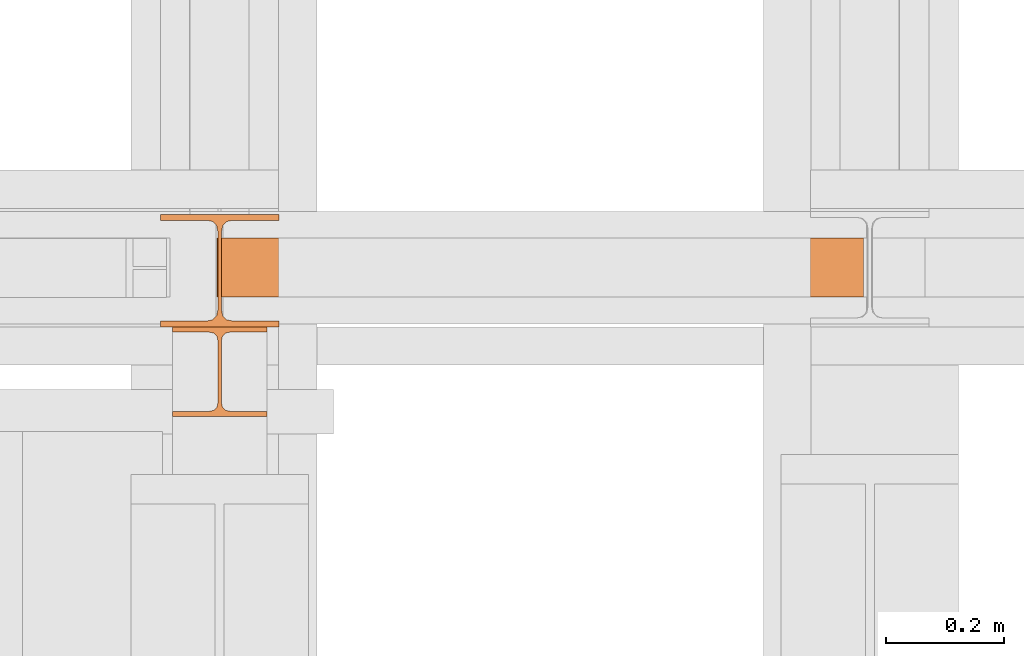
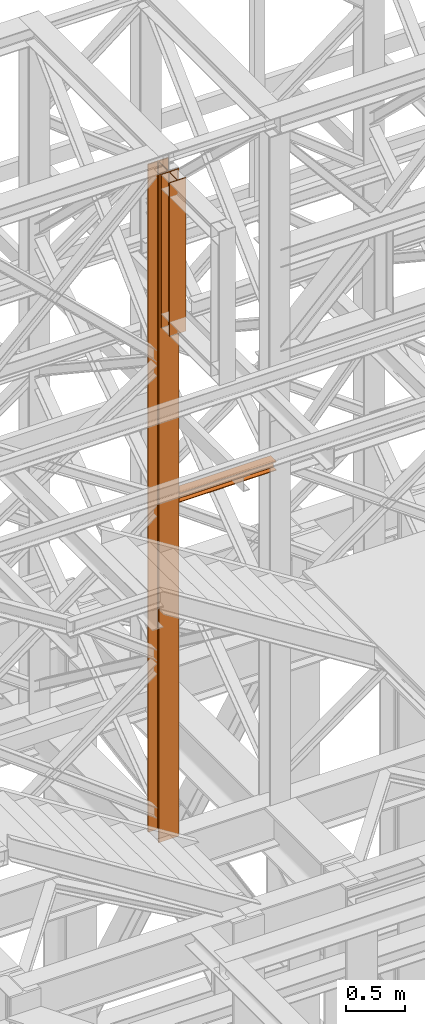
# One storey, part 91 of 208: 3 proxies.
"""IFC2X3 building model written with IfcOpenShell, lengths in millimetres."""

from ifc_helpers import new_model, entity, si_unit, converted_unit, frame, origin, origin_with_axes, place, context, subcontext, project, spatial, faceted_brep, element, save


model = new_model("IFC2X3")

# Units and contexts
model_context = context("Model", 3, precision=1e-05, world=origin())
plan_context = context("Plan", 3, precision=1e-05, world=origin())
body_context = subcontext(model_context, "Body", "Model", "MODEL_VIEW")
ifc_project = project(units=[si_unit("LENGTHUNIT", "METRE", prefix="MILLI"), converted_unit("PLANEANGLEUNIT", "DEGREE", entity("IfcPlaneAngleMeasure", 0.0174532925199433), si_unit("PLANEANGLEUNIT", "RADIAN"), dimensions=[0, 0, 0, 0, 0, 0, 0]), si_unit("AREAUNIT", "SQUARE_METRE"), si_unit("VOLUMEUNIT", "CUBIC_METRE")], contexts=[model_context, plan_context])

# Building, storey
building_placement = place(None, origin())
building = spatial("IfcBuilding", under=ifc_project, at=building_placement, CompositionType="COMPLEX")
storey_placement = place(building_placement, origin_with_axes())
storey = spatial("IfcBuildingStorey", under=building, at=storey_placement, Name="Geschoss", CompositionType="ELEMENT")

# Proxies
proxy_1_placement = place(storey_placement, frame((-1206.582754329112, -16062.574391808, 5284.990005364419), z_axis=(0.0, 0.0, 1.0), x_axis=(1.0, 0.0, 0.0)))
element("IfcBuildingElementProxy", 1, at=proxy_1_placement, inside=storey, context=body_context, shape_type="Brep", body=[
    faceted_brep([(0.009999999999990905, 190.0100125169756, 6965.010053329391), (200.0100029802322, 190.0100125169756, 6965.010053329391), (200.0100029802322, 180.0100146031382, 6965.010053329391), (121.2600035762787, 180.0100071525576, 6965.010053329391), (111.9441915473342, 178.1454621052744, 6965.010053329391), (105.1245498640835, 171.3258190250399, 6965.010053329391), (103.2600015571713, 162.010007927418, 6965.010053329391), (103.2600015571713, 28.00999713897727, 6965.010053329391), (105.1245498640835, 18.69418604135535, 6965.010053329391), (111.9441915473342, 11.87454296112082, 6965.010053329391), (121.2600035762787, 10.00999791383765, 6965.010053329391), (200.0100029802322, 10.00999791383765, 6965.010053329391), (200.0100029802322, 0.01000000000021828, 6965.010053329391), (0.009999999999990905, 0.01000000000021828, 6965.010053329391), (0.009999999999990905, 10.00999791383765, 6965.010053329391), (78.75999940395354, 10.00999791383765, 6965.010053329391), (88.07581143289804, 11.87454296112082, 6965.010053329391), (94.8954531161487, 18.69418604135535, 6965.010053329391), (96.76000142306088, 28.00999713897727, 6965.010053329391), (96.76000142306088, 162.010007927418, 6965.010053329391), (94.8954531161487, 171.3258190250399, 6965.010053329391), (88.07581143289804, 178.1454621052744, 6965.010053329391), (78.75999940395354, 180.0100071525576, 6965.010053329391), (0.009999999999990905, 180.0100146031382, 6965.010053329391), (200.0100029802322, 190.0100125169756, 6965.010053329391), (0.009999999999990905, 190.0100125169756, 6965.010053329391), (0.009999999999990905, 190.0100125169756, 0.009999999999308784), (200.0100029802322, 190.0100125169756, 0.009999999999308784), (200.0100029802322, 180.0100146031382, 6965.010053329391), (200.0100029802322, 190.0100125169756, 6965.010053329391), (200.0100029802322, 190.0100125169756, 0.009999999999308784), (200.0100029802322, 180.0100146031382, 0.009999999999308784), (121.2600035762787, 180.0100071525576, 6965.010053329391), (200.0100029802322, 180.0100146031382, 6965.010053329391), (200.0100029802322, 180.0100146031382, 0.009999999999308784), (121.2600035762787, 180.0100071525576, 0.009999999999308784), (111.9441915473342, 178.1454621052744, 6965.010053329391), (121.2600035762787, 180.0100071525576, 6965.010053329391), (121.2600035762787, 180.0100071525576, 0.009999999999308784), (111.9441915473342, 178.1454621052744, 0.009999999999308784), (105.1245498640835, 171.3258190250399, 6965.010053329391), (111.9441915473342, 178.1454621052744, 6965.010053329391), (111.9441915473342, 178.1454621052744, 0.009999999999308784), (105.1245498640835, 171.3258190250399, 0.009999999999308784), (103.2600015571713, 162.010007927418, 6965.010053329391), (105.1245498640835, 171.3258190250399, 6965.010053329391), (105.1245498640835, 171.3258190250399, 0.009999999999308784), (103.2600015571713, 162.010007927418, 0.009999999999308784), (103.2600015571713, 28.00999713897727, 6965.010053329391), (103.2600015571713, 162.010007927418, 6965.010053329391), (103.2600015571713, 162.010007927418, 0.009999999999308784), (103.2600015571713, 28.00999713897727, 0.009999999999308784), (105.1245498640835, 18.69418604135535, 6965.010053329391), (103.2600015571713, 28.00999713897727, 6965.010053329391), (103.2600015571713, 28.00999713897727, 0.009999999999308784), (105.1245498640835, 18.69418604135535, 0.009999999999308784), (111.9441915473342, 11.87454296112082, 6965.010053329391), (105.1245498640835, 18.69418604135535, 6965.010053329391), (105.1245498640835, 18.69418604135535, 0.009999999999308784), (111.9441915473342, 11.87454296112082, 0.009999999999308784), (121.2600035762787, 10.00999791383765, 6965.010053329391), (111.9441915473342, 11.87454296112082, 6965.010053329391), (111.9441915473342, 11.87454296112082, 0.009999999999308784), (121.2600035762787, 10.00999791383765, 0.009999999999308784), (200.0100029802322, 10.00999791383765, 6965.010053329391), (121.2600035762787, 10.00999791383765, 6965.010053329391), (121.2600035762787, 10.00999791383765, 0.009999999999308784), (200.0100029802322, 10.00999791383765, 0.009999999999308784), (200.0100029802322, 0.01000000000021828, 6965.010053329391), (200.0100029802322, 10.00999791383765, 6965.010053329391), (200.0100029802322, 10.00999791383765, 0.009999999999308784), (200.0100029802322, 0.01000000000021828, 0.009999999999308784), (0.009999999999990905, 0.01000000000021828, 6965.010053329391), (200.0100029802322, 0.01000000000021828, 6965.010053329391), (200.0100029802322, 0.01000000000021828, 0.009999999999308784), (0.009999999999990905, 0.01000000000021828, 0.009999999999308784), (0.009999999999990905, 10.00999791383765, 6965.010053329391), (0.009999999999990905, 0.01000000000021828, 6965.010053329391), (0.009999999999990905, 0.01000000000021828, 0.009999999999308784), (0.009999999999990905, 10.00999791383765, 0.009999999999308784), (78.75999940395354, 10.00999791383765, 6965.010053329391), (0.009999999999990905, 10.00999791383765, 6965.010053329391), (0.009999999999990905, 10.00999791383765, 0.009999999999308784), (78.75999940395354, 10.00999791383765, 0.009999999999308784), (88.07581143289804, 11.87454296112082, 6965.010053329391), (78.75999940395354, 10.00999791383765, 6965.010053329391), (78.75999940395354, 10.00999791383765, 0.009999999999308784), (88.07581143289804, 11.87454296112082, 0.009999999999308784), (94.8954531161487, 18.69418604135535, 6965.010053329391), (88.07581143289804, 11.87454296112082, 6965.010053329391), (88.07581143289804, 11.87454296112082, 0.009999999999308784), (94.8954531161487, 18.69418604135535, 0.009999999999308784), (96.76000142306088, 28.00999713897727, 6965.010053329391), (94.8954531161487, 18.69418604135535, 6965.010053329391), (94.8954531161487, 18.69418604135535, 0.009999999999308784), (96.76000142306088, 28.00999713897727, 0.009999999999308784), (96.76000142306088, 162.010007927418, 6965.010053329391), (96.76000142306088, 28.00999713897727, 6965.010053329391), (96.76000142306088, 28.00999713897727, 0.009999999999308784), (96.76000142306088, 162.010007927418, 0.009999999999308784), (94.8954531161487, 171.3258190250399, 6965.010053329391), (96.76000142306088, 162.010007927418, 6965.010053329391), (96.76000142306088, 162.010007927418, 0.009999999999308784), (94.8954531161487, 171.3258190250399, 0.009999999999308784), (88.07581143289804, 178.1454621052744, 6965.010053329391), (94.8954531161487, 171.3258190250399, 6965.010053329391), (94.8954531161487, 171.3258190250399, 0.009999999999308784), (88.07581143289804, 178.1454621052744, 0.009999999999308784), (78.75999940395354, 180.0100071525576, 6965.010053329391), (88.07581143289804, 178.1454621052744, 6965.010053329391), (88.07581143289804, 178.1454621052744, 0.009999999999308784), (78.75999940395354, 180.0100071525576, 0.009999999999308784), (0.009999999999990905, 180.0100146031382, 6965.010053329391), (78.75999940395354, 180.0100071525576, 6965.010053329391), (78.75999940395354, 180.0100071525576, 0.009999999999308784), (0.009999999999990905, 180.0100146031382, 0.009999999999308784), (0.009999999999990905, 190.0100125169756, 6965.010053329391), (0.009999999999990905, 180.0100146031382, 6965.010053329391), (0.009999999999990905, 180.0100146031382, 0.009999999999308784), (0.009999999999990905, 190.0100125169756, 0.009999999999308784), (0.009999999999990905, 190.0100125169756, 0.009999999999308784), (0.009999999999990905, 180.0100146031382, 0.009999999999308784), (78.75999940395354, 180.0100071525576, 0.009999999999308784), (88.07581143289804, 178.1454621052744, 0.009999999999308784), (94.8954531161487, 171.3258190250399, 0.009999999999308784), (96.76000142306088, 162.010007927418, 0.009999999999308784), (96.76000142306088, 28.00999713897727, 0.009999999999308784), (94.8954531161487, 18.69418604135535, 0.009999999999308784), (88.07581143289804, 11.87454296112082, 0.009999999999308784), (78.75999940395354, 10.00999791383765, 0.009999999999308784), (0.009999999999990905, 10.00999791383765, 0.009999999999308784), (0.009999999999990905, 0.01000000000021828, 0.009999999999308784), (200.0100029802322, 0.01000000000021828, 0.009999999999308784), (200.0100029802322, 10.00999791383765, 0.009999999999308784), (121.2600035762787, 10.00999791383765, 0.009999999999308784), (111.9441915473342, 11.87454296112082, 0.009999999999308784), (105.1245498640835, 18.69418604135535, 0.009999999999308784), (103.2600015571713, 28.00999713897727, 0.009999999999308784), (103.2600015571713, 162.010007927418, 0.009999999999308784), (105.1245498640835, 171.3258190250399, 0.009999999999308784), (111.9441915473342, 178.1454621052744, 0.009999999999308784), (121.2600035762787, 180.0100071525576, 0.009999999999308784), (200.0100029802322, 180.0100146031382, 0.009999999999308784), (200.0100029802322, 190.0100125169756, 0.009999999999308784)], [[[0, 1, 2, 3, 4, 5, 6, 7, 8, 9, 10, 11, 12, 13, 14, 15, 16, 17, 18, 19, 20, 21, 22, 23]], [[24, 25, 26, 27]], [[28, 29, 30, 31]], [[32, 33, 34, 35]], [[36, 37, 38, 39]], [[40, 41, 42, 43]], [[44, 45, 46, 47]], [[48, 49, 50, 51]], [[52, 53, 54, 55]], [[56, 57, 58, 59]], [[60, 61, 62, 63]], [[64, 65, 66, 67]], [[68, 69, 70, 71]], [[72, 73, 74, 75]], [[76, 77, 78, 79]], [[80, 81, 82, 83]], [[84, 85, 86, 87]], [[88, 89, 90, 91]], [[92, 93, 94, 95]], [[96, 97, 98, 99]], [[100, 101, 102, 103]], [[104, 105, 106, 107]], [[108, 109, 110, 111]], [[112, 113, 114, 115]], [[116, 117, 118, 119]], [[120, 121, 122, 123, 124, 125, 126, 127, 128, 129, 130, 131, 132, 133, 134, 135, 136, 137, 138, 139, 140, 141, 142, 143]]], orient=[[False], [False], [False], [False], [False], [False], [False], [False], [False], [False], [False], [False], [False], [False], [False], [False], [False], [False], [False], [False], [False], [False], [False], [False], [False], [False]]),
])
proxy_2_placement = place(storey_placement, frame((-1111.071256267099, -16012.50587051043, 8720.799696083517), z_axis=(0.0, 0.0, 1.0), x_axis=(1.0, 0.0, 0.0)))
element("IfcBuildingElementProxy", 2, at=proxy_2_placement, inside=storey, context=body_context, shape_type="Brep", body=[
    faceted_brep([(1093.509999865889, 0.01000000000021828, 88.01000000000022), (1093.509999865889, 0.01000000000021828, 96.01000000000022), (1093.509999865889, 100.0100000000002, 96.01000000000022), (1093.509999865889, 100.0100000000002, 88.01000000000022), (1093.509999865889, 52.51000000000022, 88.01000000000022), (1093.509999865889, 52.51000000000022, 8.010000000000218), (1093.509999865889, 100.0100000000002, 8.010000000000218), (1093.509999865889, 100.0100000000002, 0.01000000000021828), (1093.509999865889, 0.01000000000021828, 0.01000000000021828), (1093.509999865889, 0.01000000000021828, 8.010000000000218), (1093.509999865889, 47.51000000000022, 8.010000000000218), (1093.509999865889, 47.51000000000022, 88.01000000000022), (1093.509999865889, 0.01000000000021828, 96.01000000000022), (1093.509999865889, 0.01000000000021828, 88.01000000000022), (0.009999999999990905, 0.01000000000385626, 88.01000000000022), (0.009999999999990905, 0.01000000000385626, 96.01000000000022), (1093.509999865889, 100.0100000000002, 96.01000000000022), (1093.509999865889, 0.01000000000021828, 96.01000000000022), (0.009999999999990905, 0.01000000000385626, 96.01000000000022), (0.009999999999990905, 100.0100000000039, 96.01000000000022), (1093.509999865889, 100.0100000000002, 88.01000000000022), (1093.509999865889, 100.0100000000002, 96.01000000000022), (0.009999999999990905, 100.0100000000039, 96.01000000000022), (0.009999999999990905, 100.0100000000039, 88.01000000000022), (1093.509999865889, 52.51000000000022, 88.01000000000022), (1093.509999865889, 100.0100000000002, 88.01000000000022), (0.009999999999990905, 100.0100000000039, 88.01000000000022), (0.009999999999990905, 52.51000000000386, 88.01000000000022), (1093.509999865889, 52.51000000000022, 8.010000000000218), (1093.509999865889, 52.51000000000022, 88.01000000000022), (0.009999999999990905, 52.51000000000386, 88.01000000000022), (0.009999999999990905, 52.51000000000386, 8.010000000000218), (1093.509999865889, 100.0100000000002, 8.010000000000218), (1093.509999865889, 52.51000000000022, 8.010000000000218), (0.009999999999990905, 52.51000000000386, 8.010000000000218), (0.009999999999990905, 100.0100000000039, 8.010000000000218), (1093.509999865889, 100.0100000000002, 0.01000000000021828), (1093.509999865889, 100.0100000000002, 8.010000000000218), (0.009999999999990905, 100.0100000000039, 8.010000000000218), (0.009999999999990905, 100.0100000000039, 0.01000000000021828), (1093.509999865889, 0.01000000000021828, 0.01000000000021828), (1093.509999865889, 100.0100000000002, 0.01000000000021828), (0.009999999999990905, 100.0100000000039, 0.01000000000021828), (0.009999999999990905, 0.01000000000385626, 0.01000000000021828), (1093.509999865889, 0.01000000000021828, 8.010000000000218), (1093.509999865889, 0.01000000000021828, 0.01000000000021828), (0.009999999999990905, 0.01000000000385626, 0.01000000000021828), (0.009999999999990905, 0.01000000000385626, 8.010000000000218), (1093.509999865889, 47.51000000000022, 8.010000000000218), (1093.509999865889, 0.01000000000021828, 8.010000000000218), (0.009999999999990905, 0.01000000000385626, 8.010000000000218), (0.009999999999990905, 47.51000000000386, 8.010000000000218), (1093.509999865889, 47.51000000000022, 88.01000000000022), (1093.509999865889, 47.51000000000022, 8.010000000000218), (0.009999999999990905, 47.51000000000386, 8.010000000000218), (0.009999999999990905, 47.51000000000386, 88.01000000000022), (1093.509999865889, 0.01000000000021828, 88.01000000000022), (1093.509999865889, 47.51000000000022, 88.01000000000022), (0.009999999999990905, 47.51000000000386, 88.01000000000022), (0.009999999999990905, 0.01000000000385626, 88.01000000000022), (0.009999999999990905, 0.01000000000385626, 88.01000000000022), (0.009999999999990905, 47.51000000000386, 88.01000000000022), (0.009999999999990905, 47.51000000000386, 8.010000000000218), (0.009999999999990905, 0.01000000000385626, 8.010000000000218), (0.009999999999990905, 0.01000000000385626, 0.01000000000021828), (0.009999999999990905, 100.0100000000039, 0.01000000000021828), (0.009999999999990905, 100.0100000000039, 8.010000000000218), (0.009999999999990905, 52.51000000000386, 8.010000000000218), (0.009999999999990905, 52.51000000000386, 88.01000000000022), (0.009999999999990905, 100.0100000000039, 88.01000000000022), (0.009999999999990905, 100.0100000000039, 96.01000000000022), (0.009999999999990905, 0.01000000000385626, 96.01000000000022)], [[[0, 1, 2, 3, 4, 5, 6, 7, 8, 9, 10, 11]], [[12, 13, 14, 15]], [[16, 17, 18, 19]], [[20, 21, 22, 23]], [[24, 25, 26, 27]], [[28, 29, 30, 31]], [[32, 33, 34, 35]], [[36, 37, 38, 39]], [[40, 41, 42, 43]], [[44, 45, 46, 47]], [[48, 49, 50, 51]], [[52, 53, 54, 55]], [[56, 57, 58, 59]], [[60, 61, 62, 63, 64, 65, 66, 67, 68, 69, 70, 71]]], orient=[[False], [False], [False], [False], [False], [False], [False], [False], [False], [False], [False], [False], [False], [False]]),
])
proxy_3_placement = place(storey_placement, frame((-1186.582758501437, -16214.57440182159, 10649.99005869381), z_axis=(0.0, 0.0, 1.0), x_axis=(1.0, 0.0, 0.0)))
element("IfcBuildingElementProxy", 3, at=proxy_3_placement, inside=storey, context=body_context, shape_type="Brep", body=[
    faceted_brep([(160.0100113248825, 0.01000000000021828, 0.01000000000021828), (160.0100113248825, 9.010003337860326, 0.01000000000021828), (98.01000675022601, 9.010003337860326, 0.01000000000021828), (90.24683052510022, 10.5637921190264, 0.01000000000021828), (84.56379586666822, 16.24682677745841, 0.01000000000021828), (83.01000568851828, 24.01000020861648, 0.01000000000021828), (83.01000568851828, 128.010006079674, 0.01000000000021828), (84.56379586666822, 135.7731832361224, 0.01000000000021828), (90.24683052510022, 141.4562178945544, 0.01000000000021828), (98.01000675022601, 143.0100066757204, 0.01000000000021828), (160.0100113248825, 143.0100066757204, 0.01000000000021828), (160.0100113248825, 152.0100100135805, 0.01000000000021828), (0.009999999999990905, 152.0100100135805, 0.01000000000021828), (0.009999999999990905, 143.0100066757204, 0.01000000000021828), (62.01000457465648, 143.0100066757204, 0.01000000000021828), (69.77318079978227, 141.4562178945544, 0.01000000000021828), (75.45621545821427, 135.7731832361224, 0.01000000000021828), (77.01000563636421, 128.010006079674, 0.01000000000021828), (77.01000563636421, 24.01000020861648, 0.01000000000021828), (75.45621545821427, 16.24682677745841, 0.01000000000021828), (69.77318079978227, 10.5637921190264, 0.01000000000021828), (62.01000457465648, 9.010003337860326, 0.01000000000021828), (0.009999999999990905, 9.010003337860326, 0.01000000000021828), (0.009999999999990905, 0.01000000000021828, 0.01000000000021828), (0.009999999999990905, 0.01000000000021828, 0.01000000000021828), (0.009999999999990905, 0.01000000000021828, 1600.01), (160.0100113248789, 0.01000000000021828, 1600.01), (160.0100113248825, 0.01000000000021828, 0.01000000000021828), (0.009999999999990905, 9.010003337860326, 0.01000000000021828), (0.009999999999990905, 9.010003337860326, 1600.01), (0.009999999999990905, 0.01000000000021828, 1600.01), (0.009999999999990905, 0.01000000000021828, 0.01000000000021828), (62.01000457465648, 9.010003337860326, 0.01000000000021828), (62.01000457465648, 9.010003337860326, 1600.01), (0.009999999999990905, 9.010003337860326, 1600.01), (0.009999999999990905, 9.010003337860326, 0.01000000000021828), (69.77318079978227, 10.5637921190264, 0.01000000000021828), (69.77318079977863, 10.5637921190264, 1600.01), (62.01000457465648, 9.010003337860326, 1600.01), (62.01000457465648, 9.010003337860326, 0.01000000000021828), (75.45621545821427, 16.24682677745841, 0.01000000000021828), (75.45621545821064, 16.24682677745841, 1600.01), (69.77318079977863, 10.5637921190264, 1600.01), (69.77318079978227, 10.5637921190264, 0.01000000000021828), (77.01000563636421, 24.01000020861648, 0.01000000000021828), (77.01000563636057, 24.01000020861648, 1600.01), (75.45621545821064, 16.24682677745841, 1600.01), (75.45621545821427, 16.24682677745841, 0.01000000000021828), (77.01000563636421, 128.010006079674, 0.01000000000021828), (77.01000563636057, 128.010006079674, 1600.01), (77.01000563636057, 24.01000020861648, 1600.01), (77.01000563636421, 24.01000020861648, 0.01000000000021828), (75.45621545821427, 135.7731832361224, 0.01000000000021828), (75.45621545821064, 135.7731832361224, 1600.01), (77.01000563636057, 128.010006079674, 1600.01), (77.01000563636421, 128.010006079674, 0.01000000000021828), (69.77318079978227, 141.4562178945544, 0.01000000000021828), (69.77318079977863, 141.4562178945544, 1600.01), (75.45621545821064, 135.7731832361224, 1600.01), (75.45621545821427, 135.7731832361224, 0.01000000000021828), (62.01000457465648, 143.0100066757204, 0.01000000000021828), (62.01000457465284, 143.0100066757204, 1600.01), (69.77318079977863, 141.4562178945544, 1600.01), (69.77318079978227, 141.4562178945544, 0.01000000000021828), (0.009999999999990905, 143.0100066757204, 0.01000000000021828), (0.009999999999990905, 143.0100066757204, 1600.01), (62.01000457465284, 143.0100066757204, 1600.01), (62.01000457465648, 143.0100066757204, 0.01000000000021828), (0.009999999999990905, 152.0100100135805, 0.01000000000021828), (0.009999999999990905, 152.0100100135805, 1600.01), (0.009999999999990905, 143.0100066757204, 1600.01), (0.009999999999990905, 143.0100066757204, 0.01000000000021828), (160.0100113248825, 152.0100100135805, 0.01000000000021828), (160.0100113248825, 152.0100100135842, 1600.01), (0.009999999999990905, 152.0100100135805, 1600.01), (0.009999999999990905, 152.0100100135805, 0.01000000000021828), (160.0100113248825, 143.0100066757204, 0.01000000000021828), (160.0100113248825, 143.0100066757204, 1600.01), (160.0100113248825, 152.0100100135842, 1600.01), (160.0100113248825, 152.0100100135805, 0.01000000000021828), (98.01000675022601, 143.0100066757204, 0.01000000000021828), (98.01000675022237, 143.0100066757204, 1600.01), (160.0100113248825, 143.0100066757204, 1600.01), (160.0100113248825, 143.0100066757204, 0.01000000000021828), (90.24683052510022, 141.4562178945544, 0.01000000000021828), (90.24683052509658, 141.4562178945544, 1600.01), (98.01000675022237, 143.0100066757204, 1600.01), (98.01000675022601, 143.0100066757204, 0.01000000000021828), (84.56379586666822, 135.7731832361224, 0.01000000000021828), (84.56379586666458, 135.773183236126, 1600.01), (90.24683052509658, 141.4562178945544, 1600.01), (90.24683052510022, 141.4562178945544, 0.01000000000021828), (83.01000568851828, 128.010006079674, 0.01000000000021828), (83.01000568851464, 128.0100060796776, 1600.01), (84.56379586666458, 135.773183236126, 1600.01), (84.56379586666822, 135.7731832361224, 0.01000000000021828), (83.01000568851828, 24.01000020861648, 0.01000000000021828), (83.01000568851464, 24.01000020861648, 1600.01), (83.01000568851464, 128.0100060796776, 1600.01), (83.01000568851828, 128.010006079674, 0.01000000000021828), (84.56379586666822, 16.24682677745841, 0.01000000000021828), (84.56379586666458, 16.24682677745841, 1600.01), (83.01000568851464, 24.01000020861648, 1600.01), (83.01000568851828, 24.01000020861648, 0.01000000000021828), (90.24683052510022, 10.5637921190264, 0.01000000000021828), (90.24683052509658, 10.5637921190264, 1600.01), (84.56379586666458, 16.24682677745841, 1600.01), (84.56379586666822, 16.24682677745841, 0.01000000000021828), (98.01000675022601, 9.010003337860326, 0.01000000000021828), (98.01000675022237, 9.010003337860326, 1600.01), (90.24683052509658, 10.5637921190264, 1600.01), (90.24683052510022, 10.5637921190264, 0.01000000000021828), (160.0100113248825, 9.010003337860326, 0.01000000000021828), (160.0100113248825, 9.010003337860326, 1600.01), (98.01000675022237, 9.010003337860326, 1600.01), (98.01000675022601, 9.010003337860326, 0.01000000000021828), (160.0100113248825, 0.01000000000021828, 0.01000000000021828), (160.0100113248789, 0.01000000000021828, 1600.01), (160.0100113248825, 9.010003337860326, 1600.01), (160.0100113248825, 9.010003337860326, 0.01000000000021828), (160.0100113248789, 0.01000000000021828, 1600.01), (0.009999999999990905, 0.01000000000021828, 1600.01), (0.009999999999990905, 9.010003337860326, 1600.01), (62.01000457465648, 9.010003337860326, 1600.01), (69.77318079977863, 10.5637921190264, 1600.01), (75.45621545821064, 16.24682677745841, 1600.01), (77.01000563636057, 24.01000020861648, 1600.01), (77.01000563636057, 128.010006079674, 1600.01), (75.45621545821064, 135.7731832361224, 1600.01), (69.77318079977863, 141.4562178945544, 1600.01), (62.01000457465284, 143.0100066757204, 1600.01), (0.009999999999990905, 143.0100066757204, 1600.01), (0.009999999999990905, 152.0100100135805, 1600.01), (160.0100113248825, 152.0100100135842, 1600.01), (160.0100113248825, 143.0100066757204, 1600.01), (98.01000675022237, 143.0100066757204, 1600.01), (90.24683052509658, 141.4562178945544, 1600.01), (84.56379586666458, 135.773183236126, 1600.01), (83.01000568851464, 128.0100060796776, 1600.01), (83.01000568851464, 24.01000020861648, 1600.01), (84.56379586666458, 16.24682677745841, 1600.01), (90.24683052509658, 10.5637921190264, 1600.01), (98.01000675022237, 9.010003337860326, 1600.01), (160.0100113248825, 9.010003337860326, 1600.01)], [[[0, 1, 2, 3, 4, 5, 6, 7, 8, 9, 10, 11, 12, 13, 14, 15, 16, 17, 18, 19, 20, 21, 22, 23]], [[24, 25, 26, 27]], [[28, 29, 30, 31]], [[32, 33, 34, 35]], [[36, 37, 38, 39]], [[40, 41, 42, 43]], [[44, 45, 46, 47]], [[48, 49, 50, 51]], [[52, 53, 54, 55]], [[56, 57, 58, 59]], [[60, 61, 62, 63]], [[64, 65, 66, 67]], [[68, 69, 70, 71]], [[72, 73, 74, 75]], [[76, 77, 78, 79]], [[80, 81, 82, 83]], [[84, 85, 86, 87]], [[88, 89, 90, 91]], [[92, 93, 94, 95]], [[96, 97, 98, 99]], [[100, 101, 102, 103]], [[104, 105, 106, 107]], [[108, 109, 110, 111]], [[112, 113, 114, 115]], [[116, 117, 118, 119]], [[120, 121, 122, 123, 124, 125, 126, 127, 128, 129, 130, 131, 132, 133, 134, 135, 136, 137, 138, 139, 140, 141, 142, 143]]], orient=[[False], [False], [False], [False], [False], [False], [False], [False], [False], [False], [False], [False], [False], [False], [False], [False], [False], [False], [False], [False], [False], [False], [False], [False], [False], [False]]),
])

save(model, "model.ifc")
